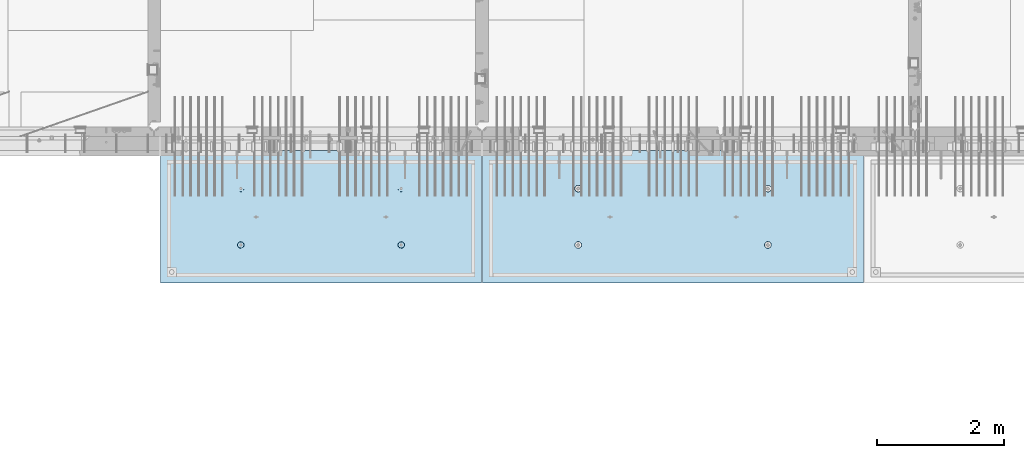
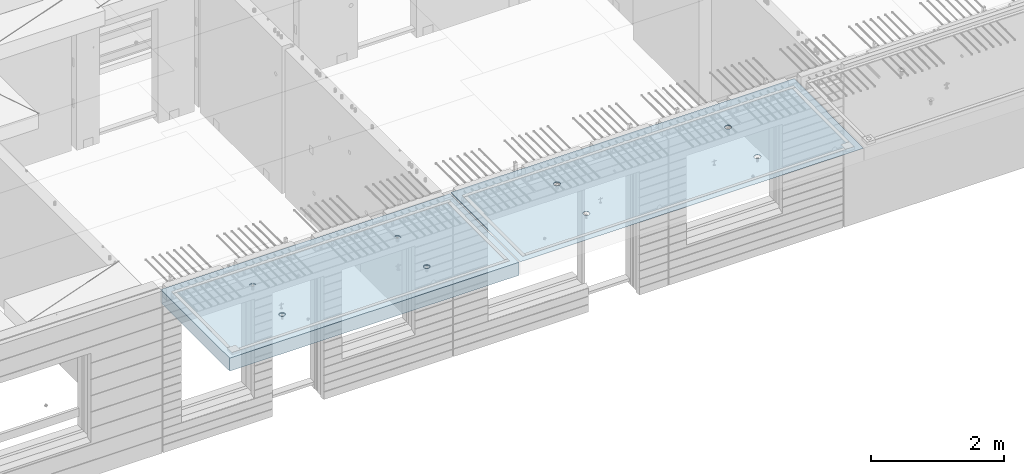
# One storey, part 201 of 349: 2 slabs, 2 elements without a shape of their own.
"""IFC2X3 building model written with IfcOpenShell, lengths in millimetres."""

from ifc_helpers import new_model, si_unit, frame, origin_with_axes, place, context, subcontext, project, spatial, faceted_brep, material, type_object, element, aggregate, save


model = new_model("IFC2X3")

# Units and contexts
model_context = context("Model", 3, precision=1e-05, world=origin_with_axes())
body_context = subcontext(model_context, "Body", "Model", "MODEL_VIEW")
ifc_project = project(units=[si_unit("LENGTHUNIT", "METRE", prefix="MILLI"), si_unit("AREAUNIT", "SQUARE_METRE"), si_unit("VOLUMEUNIT", "CUBIC_METRE"), si_unit("MASSUNIT", "GRAM", prefix="KILO"), si_unit("TIMEUNIT", "SECOND"), si_unit("PLANEANGLEUNIT", "RADIAN"), si_unit("SOLIDANGLEUNIT", "STERADIAN"), si_unit("THERMODYNAMICTEMPERATUREUNIT", "DEGREE_CELSIUS"), si_unit("LUMINOUSINTENSITYUNIT", "LUMEN")], contexts=[model_context])

# Site, building, storey
site_placement = place(None, origin_with_axes())
site = spatial("IfcSite", under=ifc_project, at=site_placement, CompositionType="ELEMENT")
building_placement = place(site_placement, origin_with_axes())
building = spatial("IfcBuilding", under=site, at=building_placement, CompositionType="ELEMENT")
storey_placement = place(building_placement, origin_with_axes())
storey = spatial("IfcBuildingStorey", under=building, at=storey_placement, Name="4", CompositionType="ELEMENT", Elevation=0.0)

# Assembly, slab
assembly_1_placement = place(storey_placement, origin_with_axes())
assembly_1 = element("IfcElementAssembly", 1, at=assembly_1_placement, inside=storey, AssemblyPlace="NOTDEFINED", PredefinedType="REINFORCEMENT_UNIT")
ifc_material = material(Name="CONCRETE/C35/45")
slab_type_1 = type_object("IfcSlabType", PredefinedType="NOTDEFINED")
slab_1_placement = place(assembly_1_placement, frame((27799.9998568133, 7629.99655735226, 93720.0), z_axis=(-1.11800000013248e-06, -0.999999999999375, 0.0), x_axis=(-0.999999999999093, 1.34699999998405e-06, 0.0)))
slab_1 = element("IfcSlab", 2, at=slab_1_placement, type_object=slab_type_1, material=ifc_material, PredefinedType="FLOOR", context=body_context, shape_type="Brep", body=[
    faceted_brep([(4430.38332613536, -4.08995228011918, 616.123557002266), (4431.90609271965, 10.0, 615.628782084005), (4439.08875686405, 10.0, 629.725594302773), (4437.8062304225, -3.95053914321761, 630.657402050439), (4450.27603094506, 10.0, 640.912894136913), (4449.35160622641, -3.83996043598745, 642.185252526786), (4464.3728266293, 10.0, 648.095590732159), (4463.88931892896, -3.76899254079035, 649.583668593681), (4479.99925133704, 10.0, 650.570591700976), (4479.99924953932, -3.74454363348195, 652.132471659324), (4495.6256817422, 10.0, 648.095626704194), (4496.1091860045, -3.76899218543258, 649.583705640341), (4509.72249396096, 10.0, 640.912962559792), (4510.64691570547, -3.83995975981816, 642.185323015524), (4520.9097937951, 10.0, 629.725688478787), (4522.19231800603, -3.95053821212787, 630.657499116635), (4528.09249039035, 10.0, 615.628892794549), (4529.6152557173, -4.08995118488383, 616.123671179757), (4530.56749135917, 10.0, 600.002468086805), (4532.18619485158, -4.24459073322942, 600.002469949934), (4528.09252636238, 10.0, 584.37603768165), (4529.64872932557, -4.39933455047139, 583.870398667863), (4520.90986221798, 10.0, 570.279225462882), (4522.24649000407, -4.53902051890327, 569.308110882728), (4509.72258813697, 10.0, 559.091925628744), (4510.70111430095, -4.6499364652409, 557.745103167879), (4495.62579245274, 10.0, 551.909229033497), (4496.142736776, -4.72117719323433, 550.318244231095), (4479.99936774499, 10.0, 549.43422806468), (4479.99936967367, -4.74573031402542, 547.758576892632), (4464.37293733984, 10.0, 551.909193061462), (4463.8559966665, -4.72117755009094, 550.318207030491), (4450.27612512107, 10.0, 559.091857205865), (4449.29760201216, -4.64993714379671, 557.745032430054), (4439.08882528693, 10.0, 570.279131286869), (4437.75219965053, -4.53902145239408, 569.308013567449), (4431.90612869169, 10.0, 584.375926971106), (4430.34992677396, -4.39933564719104, 583.87028433643), (4429.43112772287, 10.0, 600.002351678851), (4427.81242409951, -4.24459188559558, 600.002349815723), (0.0, 10.0, 0.0), (0.0, -10.0, 0.0), (0.000819232023786753, 10.0, 2085.00366210937), (5980.0, 10.0, -2.4019755073823e-09), (5980.0, -10.0, -2.4019755073823e-09), (5980.0009765625, 10.0, 2085.00366210937), (1450.3499233011, -4.39936856077111, 583.866853138679), (1451.90612877595, 10.0, 584.37249692914), (1449.43112780714, 10.0, 599.998921636884), (1447.81242044485, -4.24462478808709, 599.998919773752), (1457.75219670802, -4.53905437597132, 569.304581326389), (1459.0888253712, 10.0, 570.275701244902), (1469.29759989681, -4.64997007531929, 557.741599360567), (1470.27612520534, 10.0, 559.088427163899), (1483.85599559418, -4.7212104867067, 550.31477342891), (1484.3729374241, 10.0, 551.905763019495), (1499.99936975794, -4.74576325241651, 547.755143107666), (1499.99936782926, 10.0, 549.430798022713), (1516.14273801685, -4.72121012986463, 550.314810629518), (1515.62579253701, 10.0, 551.905798991532), (1530.70111658485, -4.64996939677803, 557.741670098397), (1529.72258822124, 10.0, 559.088495586778), (1542.24649311513, -4.53905344249506, 569.304678641675), (1540.90986230225, 10.0, 570.275795420916), (1549.64873296696, -4.39936746405147, 583.866967470121), (1548.09252644665, 10.0, 584.372607639683), (1552.18619867476, -4.24462363570638, 599.999039907971), (1550.56749144343, 10.0, 599.999038044839), (1549.61525935629, -4.08998407628678, 616.120242292795), (1548.09249047462, 10.0, 615.625462752582), (1542.19232111321, -3.95057109353365, 630.654071270945), (1540.90979387937, 10.0, 629.72225843682), (1530.64691798548, -3.83999263332225, 642.181895995745), (1529.72249404523, 10.0, 640.909532517825), (1516.10918724295, -3.76902505384351, 649.580279150618), (1515.62568182647, 10.0, 648.092196662228), (1499.99924962358, -3.7445765001321, 652.129045352205), (1499.9992514213, 10.0, 650.56716165901), (1483.88931785903, -3.76902540921583, 649.580242103954), (1484.37282671356, 10.0, 648.092160690191), (1469.35160411493, -3.83999330949155, 642.181825507), (1470.27603102933, 10.0, 640.909464094946), (1457.80622748385, -3.9505720246525, 630.653974204743), (1459.08875694832, 10.0, 629.722164260806), (1450.3833226649, -4.08998517153668, 616.120128115297), (1451.90609280392, 10.0, 615.625352042039), (1450.18528173966, 4.08930273250735, 1468.81238974452), (1450.82407776805, 10.0, 1469.01994796889), (1448.29345879993, 10.0, 1484.99752828805), (1447.63943102495, 4.24455558012414, 1484.99752753526), (1457.61190709188, 3.94915737991687, 1454.20221107617), (1458.16818327555, 10.0, 1454.60637035917), (1469.19529226424, 3.83787679090165, 1442.60118929624), (1469.60688310596, 10.0, 1443.16769686061), (1483.80158206606, 3.76640201332339, 1435.14993064656), (1484.02047762178, 10.0, 1435.82362453319), (1499.99806458492, 3.74176847410854, 1432.58187967207), (1499.99806376637, 10.0, 1433.29304234547), (1516.19454117951, 3.76640237134416, 1435.14996796955), (1515.97564408552, 10.0, 1435.82366131359), (1530.80081379559, 3.8378774716839, 1442.60126026678), (1530.38922169525, 10.0, 1443.16776682109), (1542.38417222175, 3.94915831647813, 1454.2023087116), (1541.82789519381, 10.0, 1454.6064666515), (1549.8107639085, 4.08930383282132, 1468.81250445209), (1549.17196752123, 10.0, 1469.02006116732), (1552.35657735256, 4.24455673628836, 1484.9976480647), (1551.70254970896, 10.0, 1484.99764731191), (1549.77718017658, 4.39970502781216, 1501.17188586406), (1549.17193074083, 10.0, 1500.97522763107), (1542.32982200517, 4.53957665037888, 1515.75352812725), (1541.82782523334, 10.0, 1515.38880524079), (1530.74643689407, 4.65051889081951, 1527.31927700612), (1530.38912540293, 10.0, 1526.82747873935), (1516.16088003051, 4.72171993891243, 1534.74199930817), (1515.9755308871, 10.0, 1534.17155106677), (1499.99794405534, 4.74624892331485, 1537.2991504223), (1499.99794474251, 10.0, 1536.70213325449), (1483.83501395426, 4.72171958237595, 1534.74196213963), (1484.02036442336, 10.0, 1534.17151428637), (1469.24947414505, 4.65051821242378, 1527.31920628548), (1469.60678681363, 10.0, 1526.82740877888), (1457.66611561777, 4.53957571620413, 1515.75343074172), (1458.16811331507, 10.0, 1515.38870894846), (1450.21879098044, 4.39970392896794, 1501.17177131094), (1450.82404098765, 10.0, 1500.97511443265), (4495.97553080284, 10.0, 1534.17498110874), (4496.16087879206, 4.72175280732336, 1534.74542579789), (4479.99794397108, 4.746281789965, 1537.30257672942), (4479.99794465824, 10.0, 1536.70556329646), (4510.38912531866, 10.0, 1526.83090878132), (4510.74643461406, 4.65055176430906, 1527.3227040259), (4521.82782514907, 10.0, 1515.39223528276), (4522.32981889799, 4.53960953179921, 1515.75695597294), (4529.17193065656, 10.0, 1500.97865767303), (4529.77717653759, 4.39973791921511, 1501.17531475103), (4531.70254962468, 10.0, 1485.00107735388), (4532.35657352936, 4.24458963877987, 1485.00107810666), (4529.17196743696, 10.0, 1469.02349120928), (4529.8107602671, 4.08933674640139, 1468.81593564983), (4521.82789510954, 10.0, 1454.60989669347), (4522.38416911069, 3.94919124005537, 1454.20574095265), (4510.38922161098, 10.0, 1443.17119686305), (4510.8008115117, 3.83791040322103, 1442.60469333626), (4495.97564400126, 10.0, 1435.82709135556), (4496.19453993865, 3.76643530797446, 1435.15340157113), (4479.99806368211, 10.0, 1433.29647238744), (4479.99806450065, 3.74180141248507, 1432.58531345704), (4464.02047753751, 10.0, 1435.82705457516), (4463.80158313838, 3.76643494995369, 1435.15336424814), (4449.60688302169, 10.0, 1443.17112690258), (4449.19529437959, 3.83790972242423, 1442.60462236572), (4438.16818319128, 10.0, 1454.60980040114), (4437.61191003439, 3.94919030349411, 1454.20564331723), (4430.82407768378, 10.0, 1469.02337801086), (4430.18528521251, 4.08933564607287, 1468.81582094227), (4437.66611855642, 4.53960859763902, 1515.75685858742), (4449.24947625653, 4.65055108592787, 1527.32263330526), (4463.83501502419, 4.72175245078688, 1534.74538862936), (4427.63943467959, 4.24458848261565, 1485.00095757723), (4430.2187944509, 4.39973682038544, 1501.17520019791), (4464.02036433909, 10.0, 1534.17494432834), (4449.60678672936, 10.0, 1526.83083882084), (4438.1681132308, 10.0, 1515.39213899043), (4430.82404090338, 10.0, 1500.97854447461), (4428.29345871566, 10.0, 1485.00095833002)], [[[0, 1, 2, 3]], [[3, 2, 4, 5]], [[5, 4, 6, 7]], [[7, 6, 8, 9]], [[10, 11, 9, 8]], [[12, 13, 11, 10]], [[14, 15, 13, 12]], [[16, 17, 15, 14]], [[18, 19, 17, 16]], [[20, 21, 19, 18]], [[22, 23, 21, 20]], [[24, 25, 23, 22]], [[26, 27, 25, 24]], [[27, 26, 28, 29]], [[29, 28, 30, 31]], [[31, 30, 32, 33]], [[33, 32, 34, 35]], [[35, 34, 36, 37]], [[37, 36, 38, 39]], [[39, 38, 1, 0]], [[40, 41, 42]], [[40, 43, 44, 41]], [[43, 45, 44]], [[46, 47, 48, 49]], [[50, 51, 47, 46]], [[52, 53, 51, 50]], [[54, 55, 53, 52]], [[56, 57, 55, 54]], [[58, 59, 57, 56]], [[59, 58, 60, 61]], [[61, 60, 62, 63]], [[63, 62, 64, 65]], [[65, 64, 66, 67]], [[67, 66, 68, 69]], [[69, 68, 70, 71]], [[71, 70, 72, 73]], [[73, 72, 74, 75]], [[75, 74, 76, 77]], [[78, 79, 77, 76]], [[80, 81, 79, 78]], [[82, 83, 81, 80]], [[84, 85, 83, 82]], [[49, 48, 85, 84]], [[86, 87, 88, 89]], [[90, 91, 87, 86]], [[92, 93, 91, 90]], [[94, 95, 93, 92]], [[96, 97, 95, 94]], [[98, 99, 97, 96]], [[100, 101, 99, 98]], [[101, 100, 102, 103]], [[103, 102, 104, 105]], [[105, 104, 106, 107]], [[107, 106, 108, 109]], [[109, 108, 110, 111]], [[111, 110, 112, 113]], [[113, 112, 114, 115]], [[115, 114, 116, 117]], [[117, 116, 118, 119]], [[120, 121, 119, 118]], [[122, 123, 121, 120]], [[124, 125, 123, 122]], [[89, 88, 125, 124]], [[126, 127, 128, 129]], [[130, 131, 127, 126]], [[132, 133, 131, 130]], [[134, 135, 133, 132]], [[136, 137, 135, 134]], [[138, 139, 137, 136]], [[140, 141, 139, 138]], [[142, 143, 141, 140]], [[143, 142, 144, 145]], [[145, 144, 146, 147]], [[147, 146, 148, 149]], [[149, 148, 150, 151]], [[151, 150, 152, 153]], [[153, 152, 154, 155]], [[41, 44, 45, 42], [3, 5, 7, 9, 11, 13, 15, 17, 19, 21, 23, 25, 27, 29, 31, 33, 35, 37, 39, 0], [156, 157, 158, 128, 127, 131, 133, 135, 137, 139, 141, 143, 145, 147, 149, 151, 153, 155, 159, 160], [122, 120, 118, 116, 114, 112, 110, 108, 106, 104, 102, 100, 98, 96, 94, 92, 90, 86, 89, 124], [82, 80, 78, 76, 74, 72, 70, 68, 66, 64, 62, 60, 58, 56, 54, 52, 50, 46, 49, 84]], [[129, 128, 158, 161]], [[157, 162, 161, 158]], [[156, 163, 162, 157]], [[160, 164, 163, 156]], [[159, 165, 164, 160]], [[155, 154, 165, 159]], [[43, 40, 42, 45], [34, 32, 30, 28, 26, 24, 22, 20, 18, 16, 14, 12, 10, 8, 6, 4, 2, 1, 38, 36], [152, 150, 148, 146, 144, 142, 140, 138, 136, 134, 132, 130, 126, 129, 161, 162, 163, 164, 165, 154], [91, 93, 95, 97, 99, 101, 103, 105, 107, 109, 111, 113, 115, 117, 119, 121, 123, 125, 88, 87], [51, 53, 55, 57, 59, 61, 63, 65, 67, 69, 71, 73, 75, 77, 79, 81, 83, 85, 48, 47]]]),
])
aggregate(assembly_1, [slab_1])

assembly_2_placement = place(storey_placement, origin_with_axes())
assembly_2 = element("IfcElementAssembly", 3, at=assembly_2_placement, inside=storey, AssemblyPlace="NOTDEFINED", PredefinedType="REINFORCEMENT_UNIT")
slab_type_2 = type_object("IfcSlabType", PredefinedType="NOTDEFINED")
slab_2_placement = place(assembly_2_placement, frame((21799.9998568133, 7629.99655735226, 93590.0), z_axis=(-1.11800000013248e-06, -0.999999999999375, 0.0), x_axis=(-0.999999999999093, 1.34699999998405e-06, 0.0)))
slab_2 = element("IfcSlab", 4, at=slab_2_placement, type_object=slab_type_2, material=ifc_material, PredefinedType="FLOOR", context=body_context, shape_type="Brep", body=[
    faceted_brep([(1275.44980856604, -115.0, 552.444777751491), (1289.3882117606, -115.0, 559.546772887367), (1300.44978375459, -115.0, 570.608375101608), (1307.55174081072, -115.0, 584.54679769877), (1309.9988938901, -115.0, 599.997650760343), (1307.551698599, -115.0, 615.448497136235), (1300.44970346313, -115.0, 629.3869003308), (1289.38810124889, -115.0, 640.448472324786), (1275.44967865172, -115.0, 647.550429380917), (1259.99882559015, -115.0, 649.997582460297), (1244.54797921425, -115.0, 647.550387169195), (1230.60957601969, -115.0, 640.44839203332), (1219.54800402571, -115.0, 629.386789819078), (1212.44604696957, -115.0, 615.448367221916), (1209.9988938902, -115.0, 599.997514160343), (1212.4460891813, -115.0, 584.546667784451), (1219.54808431717, -115.0, 570.608264589886), (1230.60968653141, -115.0, 559.546692595902), (1244.54810912857, -115.0, 552.444735539769), (1259.99896219015, -115.0, 549.99758246039), (1219.08841602657, -120.0, 570.274295068632), (1211.90571640051, -120.0, 584.371089208588), (1230.27571826597, -120.0, 559.087023392896), (1244.37253202901, -120.0, 551.904362279308), (1259.99896296629, -120.0, 549.429400642209), (1275.6253871419, -120.0, 551.904404970708), (1289.72218128186, -120.0, 559.087104596764), (1300.9094529576, -120.0, 570.274406836168), (1308.09211407118, -120.0, 584.371220599207), (1310.56707570828, -120.0, 599.99765153648), (1308.09207137979, -120.0, 615.624075712098), (1300.90937175373, -120.0, 629.720869852056), (1289.72206951433, -120.0, 640.90814152779), (1275.62525575129, -120.0, 648.090802641378), (1259.99882481401, -120.0, 650.565764278478), (1244.37240063839, -120.0, 648.090759949978), (1230.27560649844, -120.0, 640.908060323922), (1219.0883348227, -120.0, 629.72075808452), (1211.90567370912, -120.0, 615.623944321479), (1209.43071207202, -120.0, 599.997513384206), (0.000328360383718973, -120.0, 2085.00366210938), (5040.00048828125, -120.0, 2085.00366210938), (5040.00048828125, 120.0, 2085.00366210938), (0.000328360383718973, 120.0, 2085.00366210938), (5040.0, -120.0, -2.18278728425503e-09), (5040.0, 120.0, -2.18278728425503e-09), (-7.27595761418343e-12, -120.0, -9.09494701772928e-13), (-7.27595761418343e-12, 120.0, -9.09494701772928e-13), (1275.44859965604, -105.0, 1437.44477775066), (1289.38700285061, -105.0, 1444.54677288654), (1300.44857484459, -105.0, 1455.60837510078), (1307.55053190072, -105.0, 1469.54679769794), (1309.9976849801, -105.0, 1484.99765075952), (1307.550489689, -105.0, 1500.44849713541), (1300.44849455313, -105.0, 1514.38690032997), (1289.38689233888, -105.0, 1525.44847232396), (1275.44846974172, -105.0, 1532.55042938009), (1259.99761668015, -105.0, 1534.99758245947), (1244.54677030425, -105.0, 1532.55038716837), (1230.60836710969, -105.0, 1525.44839203249), (1219.5467951157, -105.0, 1514.38678981825), (1212.44483805958, -105.0, 1500.44836722109), (1209.99768498019, -105.0, 1484.99751415952), (1212.44488027129, -105.0, 1469.54666778362), (1219.54687540717, -105.0, 1455.60826458906), (1230.60847762142, -105.0, 1444.54669259508), (1244.54690021857, -105.0, 1437.44473553894), (1259.99775328015, -105.0, 1434.99758245956), (1210.82376192895, -120.0, 1469.01993205604), (1208.29313952565, -120.0, 1484.99751183111), (1218.16787053537, -120.0, 1454.60635602529), (1229.60657282509, -120.0, 1443.16768498606), (1244.02016891989, -120.0, 1435.82361575756), (1259.99775560856, -120.0, 1433.29303700502), (1275.97533538363, -120.0, 1435.82365940832), (1290.38891141437, -120.0, 1443.16776801474), (1301.82758245361, -120.0, 1454.60647030446), (1309.17165168211, -120.0, 1469.02006639925), (1311.70223043464, -120.0, 1484.99765308793), (1309.17160803135, -120.0, 1500.975232863), (1301.82749942493, -120.0, 1515.38880889374), (1290.3887971352, -120.0, 1526.82747993297), (1275.97520104041, -120.0, 1534.17154916147), (1259.99761435174, -120.0, 1536.70212791401), (1244.02003457667, -120.0, 1534.17150551072), (1229.60645854592, -120.0, 1526.8273969043), (1218.16778750669, -120.0, 1515.38869461457), (1210.82371827819, -120.0, 1500.97509851978), (3795.4485995714, -105.0, 1437.44822013263), (3809.38700276596, -105.0, 1444.55021526851), (3820.44857475995, -105.0, 1455.61181748275), (3827.55053181608, -105.0, 1469.55024007991), (3829.99768489545, -105.0, 1485.00109314148), (3827.55048960436, -105.0, 1500.45193951738), (3820.44849446848, -105.0, 1514.39034271194), (3809.38689225424, -105.0, 1525.45191470593), (3795.44846965708, -105.0, 1532.55387176206), (3779.9976165955, -105.0, 1535.00102484144), (3764.54677021961, -105.0, 1532.55382955034), (3750.60836702505, -105.0, 1525.45183441446), (3739.54679503106, -105.0, 1514.39023220022), (3732.44483797493, -105.0, 1500.45180960306), (3729.99768489555, -105.0, 1485.00095654148), (3732.44488018665, -105.0, 1469.55011016559), (3739.54687532252, -105.0, 1455.61170697103), (3750.60847753677, -105.0, 1444.55013497704), (3764.54690013393, -105.0, 1437.44817792091), (3779.9977531955, -105.0, 1435.00102484153), (3730.82376184431, -120.0, 1469.023374438), (3728.293139441, -120.0, 1485.00095421308), (3738.16787045072, -120.0, 1454.60979840726), (3749.60657274045, -120.0, 1443.17112736803), (3764.02016883524, -120.0, 1435.82705813953), (3779.99775552391, -120.0, 1433.29647938699), (3795.97533529898, -120.0, 1435.82710179029), (3810.38891132972, -120.0, 1443.1712103967), (3821.82758236896, -120.0, 1454.60991268643), (3829.17165159746, -120.0, 1469.02350878122), (3831.70223035, -120.0, 1485.00109546989), (3829.1716079467, -120.0, 1500.97867524497), (3821.82749934028, -120.0, 1515.39225127571), (3810.38879705056, -120.0, 1526.83092231494), (3795.97520095576, -120.0, 1534.17499154344), (3779.99761426709, -120.0, 1536.70557029598), (3764.02003449202, -120.0, 1534.17494789268), (3749.60645846128, -120.0, 1526.83083928627), (3738.16778742204, -120.0, 1515.39213699654), (3730.82371819355, -120.0, 1500.97854090175), (3795.4498084814, -115.0, 552.448220133458), (3809.38821167596, -115.0, 559.550215269334), (3820.44978366995, -115.0, 570.611817483575), (3827.55174072608, -115.0, 584.550240080738), (3829.99889380546, -115.0, 600.00109314231), (3827.55169851435, -115.0, 615.451939518203), (3820.44970337848, -115.0, 629.390342712767), (3809.38810116424, -115.0, 640.451914706753), (3795.44967856708, -115.0, 647.553871762884), (3779.9988255055, -115.0, 650.001024842264), (3764.54797912961, -115.0, 647.553829551163), (3750.60957593505, -115.0, 640.451834415288), (3739.54800394106, -115.0, 629.390232201046), (3732.44604688493, -115.0, 615.451809603883), (3729.99889380555, -115.0, 600.000956542311), (3732.44608909665, -115.0, 584.550110166418), (3739.54808423252, -115.0, 570.611706971854), (3750.60968644677, -115.0, 559.550134977869), (3764.54810904393, -115.0, 552.448177921737), (3779.9989621055, -115.0, 550.001024842357), (3731.90571631587, -120.0, 584.374531590555), (3729.43071198737, -120.0, 600.000955766174), (3739.08841594193, -120.0, 570.277737450599), (3750.27571818133, -120.0, 559.090465774863), (3764.37253194437, -120.0, 551.907804661275), (3779.99896288164, -120.0, 549.432843024176), (3795.62538705726, -120.0, 551.907847352675), (3809.72218119721, -120.0, 559.090546978732), (3820.90945287295, -120.0, 570.277849218135), (3828.09211398654, -120.0, 584.374662981175), (3830.56707562364, -120.0, 600.001093918447), (3828.09207129514, -120.0, 615.627518094066), (3820.90937166908, -120.0, 629.724312234023), (3809.72206942968, -120.0, 640.911583909758), (3795.62525566664, -120.0, 648.094245023345), (3779.99882472937, -120.0, 650.569206660445), (3764.37240055375, -120.0, 648.094202331945), (3750.27560641379, -120.0, 640.911502705889), (3739.08833473806, -120.0, 629.724200466487), (3731.90567362447, -120.0, 615.627386703446)], [[[0, 1, 2, 3, 4, 5, 6, 7, 8, 9, 10, 11, 12, 13, 14, 15, 16, 17, 18, 19]], [[20, 16, 15, 21]], [[22, 17, 16, 20]], [[23, 18, 17, 22]], [[24, 19, 18, 23]], [[25, 0, 19, 24]], [[26, 1, 0, 25]], [[27, 2, 1, 26]], [[28, 3, 2, 27]], [[29, 4, 3, 28]], [[30, 5, 4, 29]], [[31, 6, 5, 30]], [[32, 7, 6, 31]], [[33, 8, 7, 32]], [[34, 9, 8, 33]], [[35, 10, 9, 34]], [[36, 11, 10, 35]], [[37, 12, 11, 36]], [[38, 13, 12, 37]], [[39, 14, 13, 38]], [[21, 15, 14, 39]], [[40, 41, 42, 43]], [[41, 44, 45, 42]], [[44, 46, 47, 45]], [[42, 45, 47, 43]], [[46, 40, 43, 47]], [[48, 49, 50, 51, 52, 53, 54, 55, 56, 57, 58, 59, 60, 61, 62, 63, 64, 65, 66, 67]], [[68, 63, 62, 69]], [[70, 64, 63, 68]], [[71, 65, 64, 70]], [[72, 66, 65, 71]], [[73, 67, 66, 72]], [[74, 48, 67, 73]], [[75, 49, 48, 74]], [[76, 50, 49, 75]], [[77, 51, 50, 76]], [[78, 52, 51, 77]], [[79, 53, 52, 78]], [[80, 54, 53, 79]], [[81, 55, 54, 80]], [[82, 56, 55, 81]], [[83, 57, 56, 82]], [[84, 58, 57, 83]], [[85, 59, 58, 84]], [[86, 60, 59, 85]], [[87, 61, 60, 86]], [[69, 62, 61, 87]], [[88, 89, 90, 91, 92, 93, 94, 95, 96, 97, 98, 99, 100, 101, 102, 103, 104, 105, 106, 107]], [[108, 103, 102, 109]], [[110, 104, 103, 108]], [[111, 105, 104, 110]], [[112, 106, 105, 111]], [[113, 107, 106, 112]], [[114, 88, 107, 113]], [[115, 89, 88, 114]], [[116, 90, 89, 115]], [[117, 91, 90, 116]], [[118, 92, 91, 117]], [[119, 93, 92, 118]], [[120, 94, 93, 119]], [[121, 95, 94, 120]], [[122, 96, 95, 121]], [[123, 97, 96, 122]], [[124, 98, 97, 123]], [[125, 99, 98, 124]], [[126, 100, 99, 125]], [[127, 101, 100, 126]], [[109, 102, 101, 127]], [[128, 129, 130, 131, 132, 133, 134, 135, 136, 137, 138, 139, 140, 141, 142, 143, 144, 145, 146, 147]], [[148, 143, 142, 149]], [[150, 144, 143, 148]], [[151, 145, 144, 150]], [[152, 146, 145, 151]], [[153, 147, 146, 152]], [[154, 128, 147, 153]], [[155, 129, 128, 154]], [[156, 130, 129, 155]], [[157, 131, 130, 156]], [[158, 132, 131, 157]], [[159, 133, 132, 158]], [[160, 134, 133, 159]], [[161, 135, 134, 160]], [[162, 136, 135, 161]], [[163, 137, 136, 162]], [[164, 138, 137, 163]], [[165, 139, 138, 164]], [[166, 140, 139, 165]], [[167, 141, 140, 166]], [[149, 142, 141, 167]], [[44, 41, 40, 46], [37, 36, 35, 34, 33, 32, 31, 30, 29, 28, 27, 26, 25, 24, 23, 22, 20, 21, 39, 38], [166, 165, 164, 163, 162, 161, 160, 159, 158, 157, 156, 155, 154, 153, 152, 151, 150, 148, 149, 167], [126, 125, 124, 123, 122, 121, 120, 119, 118, 117, 116, 115, 114, 113, 112, 111, 110, 108, 109, 127], [86, 85, 84, 83, 82, 81, 80, 79, 78, 77, 76, 75, 74, 73, 72, 71, 70, 68, 69, 87]]]),
])
aggregate(assembly_2, [slab_2])

save(model, "model.ifc")
